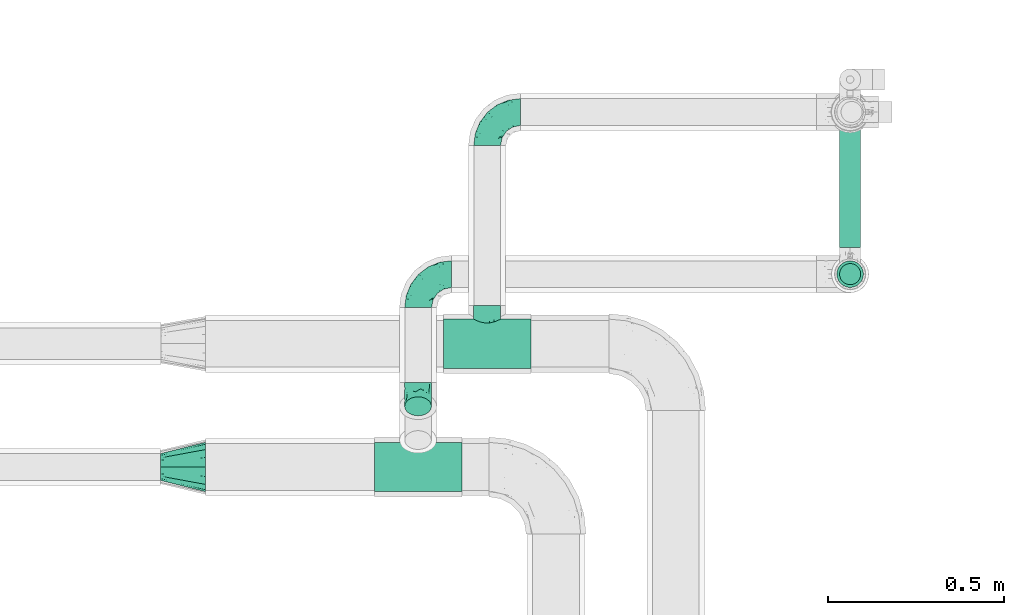
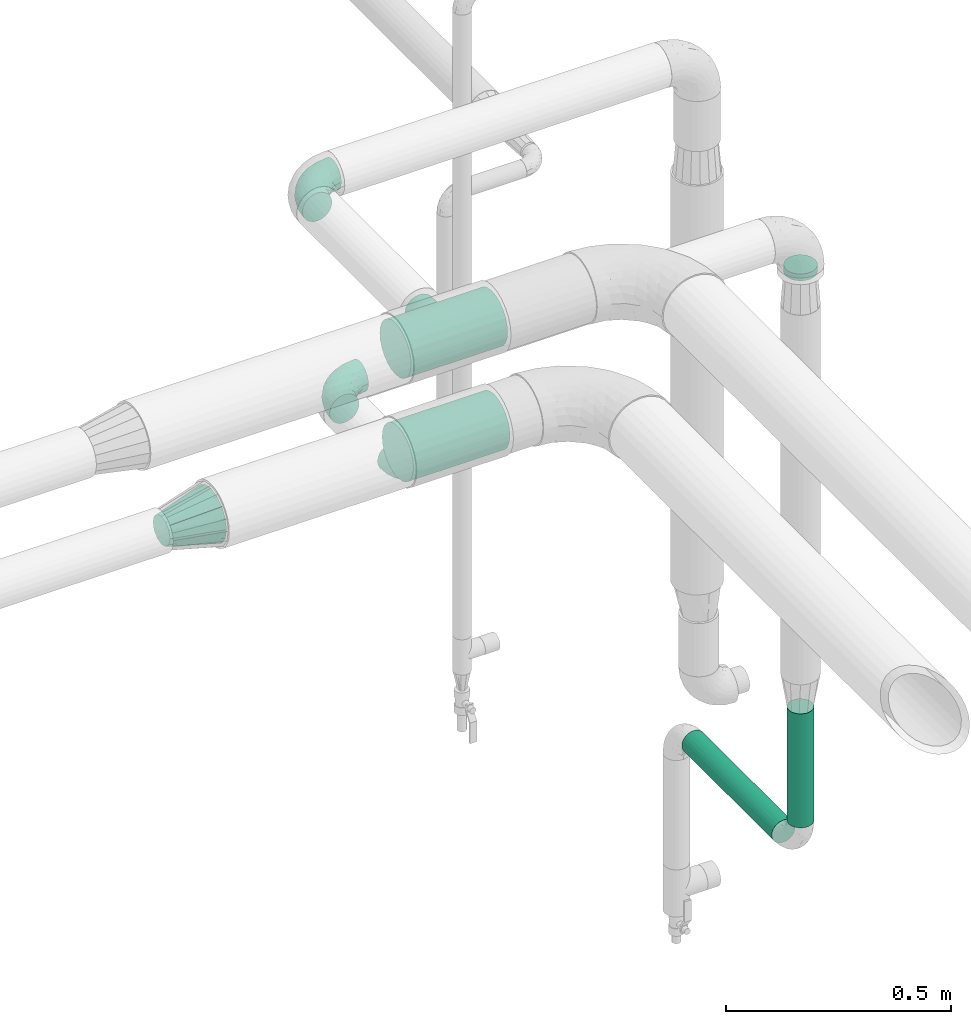
# One storey, part 583 of 827: 6 flow fittings, 3 flow segments.
"""IFC2X3 building model written with IfcOpenShell, lengths in millimetres."""

from ifc_helpers import new_model, entity, si_unit, converted_unit, derived_unit, direction, frame, origin, origin_2d_with_axis, place, context, subcontext, project, spatial, circle, extrude, faceted_brep, source, transform, mapped, material, type_object, type_shapes, element, save


model = new_model("IFC2X3")

# Units and contexts
model_context = context("Model", 3, precision=0.01, world=origin(), true_north=direction((6.12303176911189e-17, 1.0)))
body_context = subcontext(model_context, "Body", "Model", "MODEL_VIEW")
ifc_project = project(units=[si_unit("LENGTHUNIT", "METRE", prefix="MILLI"), si_unit("AREAUNIT", "SQUARE_METRE"), si_unit("VOLUMEUNIT", "CUBIC_METRE"), converted_unit("PLANEANGLEUNIT", "DEGREE", entity("IfcRatioMeasure", 0.0174532925199433), si_unit("PLANEANGLEUNIT", "RADIAN"), dimensions=[0, 0, 0, 0, 0, 0, 0]), si_unit("MASSUNIT", "GRAM", prefix="KILO"), derived_unit("MASSDENSITYUNIT", [(si_unit("MASSUNIT", "GRAM", prefix="KILO"), 1), (si_unit("LENGTHUNIT", "METRE"), -3)]), derived_unit("MOMENTOFINERTIAUNIT", [(si_unit("LENGTHUNIT", "METRE"), 4)]), si_unit("TIMEUNIT", "SECOND"), si_unit("FREQUENCYUNIT", "HERTZ"), si_unit("THERMODYNAMICTEMPERATUREUNIT", "DEGREE_CELSIUS"), derived_unit("THERMALTRANSMITTANCEUNIT", [(si_unit("MASSUNIT", "GRAM", prefix="KILO"), 1), (si_unit("THERMODYNAMICTEMPERATUREUNIT", "KELVIN"), -1), (si_unit("TIMEUNIT", "SECOND"), -3)]), derived_unit("VOLUMETRICFLOWRATEUNIT", [(si_unit("LENGTHUNIT", "METRE"), 3), (si_unit("TIMEUNIT", "SECOND"), -1)]), derived_unit("MASSFLOWRATEUNIT", [(si_unit("MASSUNIT", "GRAM", prefix="KILO"), 1), (si_unit("TIMEUNIT", "SECOND"), -1)]), derived_unit("ROTATIONALFREQUENCYUNIT", [(si_unit("TIMEUNIT", "SECOND"), -1)]), si_unit("ELECTRICCURRENTUNIT", "AMPERE"), si_unit("ELECTRICVOLTAGEUNIT", "VOLT"), si_unit("POWERUNIT", "WATT"), si_unit("FORCEUNIT", "NEWTON", prefix="KILO"), si_unit("ILLUMINANCEUNIT", "LUX"), si_unit("LUMINOUSFLUXUNIT", "LUMEN"), si_unit("LUMINOUSINTENSITYUNIT", "CANDELA"), derived_unit("USERDEFINED", [(si_unit("MASSUNIT", "GRAM", prefix="KILO"), -1), (si_unit("LENGTHUNIT", "METRE"), -2), (si_unit("TIMEUNIT", "SECOND"), 3), (si_unit("LUMINOUSFLUXUNIT", "LUMEN"), 1)]), derived_unit("LINEARVELOCITYUNIT", [(si_unit("LENGTHUNIT", "METRE"), 1), (si_unit("TIMEUNIT", "SECOND"), -1)]), si_unit("PRESSUREUNIT", "PASCAL"), derived_unit("USERDEFINED", [(si_unit("LENGTHUNIT", "METRE"), -2), (si_unit("MASSUNIT", "GRAM", prefix="KILO"), 1), (si_unit("TIMEUNIT", "SECOND"), -2)]), derived_unit("LINEARFORCEUNIT", [(si_unit("MASSUNIT", "GRAM", prefix="KILO"), 1), (si_unit("LENGTHUNIT", "METRE"), 1), (si_unit("TIMEUNIT", "SECOND"), -2), (si_unit("LENGTHUNIT", "METRE"), -1)]), derived_unit("PLANARFORCEUNIT", [(si_unit("MASSUNIT", "GRAM", prefix="KILO"), 1), (si_unit("LENGTHUNIT", "METRE"), 1), (si_unit("TIMEUNIT", "SECOND"), -2), (si_unit("LENGTHUNIT", "METRE"), -2)])], contexts=[model_context])

# Site, building, storey
site_placement = place(None, origin())
site = spatial("IfcSite", under=ifc_project, at=site_placement, CompositionType="ELEMENT")
building_placement = place(site_placement, origin())
building = spatial("IfcBuilding", under=site, at=building_placement, CompositionType="ELEMENT")
storey_placement = place(building_placement, frame((0.0, 0.0, 28200.0)))
storey = spatial("IfcBuildingStorey", under=building, at=storey_placement, Name="08", CompositionType="ELEMENT", Elevation=28200.0)

# Flow segments
pipe_segment_type = type_object("IfcPipeSegmentType", PredefinedType="NOTDEFINED")
flow_segment_1_placement = place(storey_placement, frame((22630.11, 14907.9, 2486.5)))
element("IfcFlowSegment", 1, at=flow_segment_1_placement, inside=storey, type_object=pipe_segment_type, context=body_context, shape_type="SweptSolid", body=[
    extrude(circle(Radius=37.75, at=origin_2d_with_axis()), frame((39.35, 39.35, 0.0)), (0.0, 0.0, 1.0), 18.5029617016286),
])
flow_segment_2_placement = place(storey_placement, frame((22637.86, 14915.65, 996.55)))
element("IfcFlowSegment", 2, at=flow_segment_2_placement, inside=storey, type_object=pipe_segment_type, context=body_context, shape_type="SweptSolid", body=[
    extrude(circle(Radius=30.0, at=origin_2d_with_axis()), frame((31.6, 31.6, 0.0), z_axis=(0.0, 0.0, 1.0), x_axis=(-1.0, 0.0, 0.0)), (0.0, 0.0, 1.0), 309.000000000012),
])
flow_segment_3_placement = place(storey_placement, frame((22637.86, 15023.25, 888.96)))
element("IfcFlowSegment", 3, at=flow_segment_3_placement, inside=storey, type_object=pipe_segment_type, context=body_context, shape_type="SweptSolid", body=[
    extrude(circle(Radius=30.0, at=origin_2d_with_axis()), frame((31.6, 0.0, 31.6), z_axis=(0.0, 1.0, 0.0), x_axis=(1.0, 0.0, 0.0)), (0.0, 0.0, 1.0), 400.085432468071),
])

# Flow fittings
ifc_material = material()
pipe_fitting_type_1 = type_object("IfcPipeFittingType", Name="ADSK_1", PredefinedType="NOTDEFINED", material=ifc_material)
shared_shape_1 = source(origin(), body_context, "Body", "Brep", [
    faceted_brep([(-95.0, 19.02, -32.95), (-95.0, 9.85, -36.75), (-95.0, 0.0, -38.05), (-95.0, -9.85, -36.75), (-95.0, -19.03, -32.95), (-95.0, -26.91, -26.91), (-95.0, -32.95, -19.03), (-95.0, -36.75, -9.85), (-95.0, -38.05, 0.0), (-95.0, -36.75, 9.85), (-95.0, -32.95, 19.02), (-95.0, -26.91, 26.91), (-95.0, -19.03, 32.95), (-95.0, -9.85, 36.75), (-95.0, 0.0, 38.05), (-95.0, 9.85, 36.75), (-95.0, 19.02, 32.95), (-95.0, 26.91, 26.91), (-95.0, 32.95, 19.02), (-95.0, 36.75, 9.85), (-95.0, 38.05, 0.0), (-95.0, 36.75, -9.85), (-95.0, 32.95, -19.03), (-95.0, 26.91, -26.91), (0.0, 95.0, -38.05), (-9.85, 95.0, -36.75), (-19.02, 95.0, -32.95), (-26.91, 95.0, -26.91), (-32.95, 95.0, -19.03), (-36.75, 95.0, -9.85), (-38.05, 95.0, 0.0), (-36.75, 95.0, 9.85), (-32.95, 95.0, 19.02), (-26.91, 95.0, 26.91), (-19.02, 95.0, 32.95), (-9.85, 95.0, 36.75), (0.0, 95.0, 38.05), (9.85, 95.0, 36.75), (19.03, 95.0, 32.95), (26.91, 95.0, 26.91), (32.95, 95.0, 19.02), (36.75, 95.0, 9.85), (38.05, 95.0, 0.0), (36.75, 95.0, -9.85), (32.95, 95.0, -19.03), (26.91, 95.0, -26.91), (19.03, 95.0, -32.95), (9.85, 95.0, -36.75), (-7.99, -4.96, 6.3), (-0.92, 0.92, 0.0), (4.62, 8.1, 8.01), (-76.19, -35.57, 0.0), (-64.32, -32.32, 12.43), (20.51, 62.45, 28.68), (-60.56, -33.52, 0.0), (-70.4, -13.47, 34.42), (-39.61, -5.88, 32.32), (-49.6, 2.07, 37.1), (-70.34, -28.81, 21.71), (14.64, 40.81, 26.5), (5.88, 39.61, 32.32), (3.59, 20.77, 25.31), (-40.45, 68.06, 16.75), (-62.45, -20.51, 28.68), (-44.52, -26.87, 0.0), (-28.47, -20.22, 0.0), (-26.43, -17.83, 8.75), (-76.1, 39.63, 10.76), (-72.74, 37.58, 18.19), (-60.35, 46.18, 14.61), (-13.4, 13.4, 32.12), (-20.77, -3.59, 25.31), (-14.66, 81.47, 35.56), (-6.22, 71.26, 37.92), (-57.5, 42.48, 22.79), (-15.0, 34.74, 37.7), (-27.1, 12.08, 36.05), (-9.2, 28.81, 35.63), (-79.98, 23.7, 30.95), (-73.68, -4.3, 37.48), (-30.74, 21.67, 37.97), (-62.36, 47.59, 6.79), (-72.71, 32.83, 24.69), (-67.42, 7.02, 37.95), (-32.13, 75.27, 24.51), (-43.46, 51.47, 26.26), (-24.98, 73.15, 31.29), (20.59, 41.28, 19.85), (7.79, 16.09, 15.86), (-73.21, 42.39, 0.0), (-54.73, 54.73, 0.0), (-73.44, 15.79, 35.79), (-5.94, 4.32, 20.43), (28.81, 70.34, 21.71), (32.32, 64.32, 12.43), (-53.59, 26.2, 35.09), (-52.02, 19.31, 37.21), (21.38, 33.53, 10.34), (26.87, 44.52, 0.0), (-48.28, 12.14, 38.05), (4.3, 73.68, 37.48), (-44.08, -25.52, 12.79), (-41.28, -20.59, 19.85), (35.57, 76.19, 0.0), (-47.26, 54.3, 20.18), (-47.4, 61.99, 8.58), (-42.39, 73.21, 0.0), (-39.67, 78.86, 7.21), (-45.69, 36.84, 33.11), (-32.83, 50.13, 33.35), (13.47, 70.4, 34.42), (-18.25, 63.73, 36.07), (-40.63, -13.75, 27.22), (-16.63, 46.37, 37.95), (-53.47, 38.79, 28.59), (-26.07, 48.54, 36.15), (-34.51, 34.51, 36.86), (-2.07, 49.6, 37.1), (-22.79, -10.49, 19.23), (-61.73, 28.67, 31.87), (9.65, 14.7, 0.0), (20.22, 28.47, 0.0), (33.52, 60.56, 0.0), (-11.42, -5.44, 13.25), (-14.7, -9.65, 0.0), (-81.47, 14.66, -35.56), (-62.45, -20.51, -28.68), (-71.26, 6.22, -37.92), (-75.27, 32.13, -24.51), (-73.15, 24.98, -31.29), (13.47, 70.4, -34.42), (5.88, 39.61, -32.32), (-2.07, 49.6, -37.1), (-78.86, 39.67, -7.21), (-70.4, -13.47, -34.42), (-39.61, -5.88, -32.32), (-61.99, 47.4, -8.58), (32.32, 64.32, -12.43), (28.81, 70.34, -21.71), (-63.73, 18.25, -36.07), (-50.13, 32.83, -33.35), (4.3, 73.68, -37.48), (-7.02, 67.42, -37.95), (-39.63, 76.1, -10.76), (-46.18, 60.35, -14.61), (-47.59, 62.36, -6.79), (-64.32, -32.32, -12.43), (-26.2, 53.59, -35.09), (-15.79, 73.44, -35.79), (-19.31, 52.02, -37.21), (-37.58, 72.74, -18.19), (-70.34, -28.81, -21.71), (-42.48, 57.5, -22.79), (-38.79, 53.47, -28.59), (-51.47, 43.46, -26.26), (-32.83, 72.71, -24.69), (-46.37, 16.63, -37.95), (-73.68, -4.3, -37.48), (-41.28, -20.59, -19.85), (-44.08, -25.52, -12.79), (13.75, 40.63, -27.22), (20.51, 62.45, -28.68), (-68.06, 40.45, -16.75), (-54.3, 47.26, -20.18), (-12.14, 48.28, -38.05), (-21.67, 30.74, -37.97), (-36.84, 45.69, -33.11), (-11.42, -5.44, -13.25), (7.79, 16.09, -15.86), (4.62, 8.1, -8.01), (-23.7, 79.98, -30.95), (-26.43, -17.83, -8.75), (-7.99, -4.96, -6.3), (-40.81, -14.64, -26.5), (-20.77, -3.59, -25.31), (-34.74, 15.0, -37.7), (-12.08, 27.1, -36.05), (-28.81, 9.2, -35.63), (-22.79, -10.49, -19.23), (21.38, 33.53, -10.34), (20.59, 41.28, -19.85), (-48.54, 26.07, -36.15), (-49.6, 2.07, -37.1), (-13.4, 13.4, -32.12), (3.59, 20.77, -25.31), (-28.67, 61.73, -31.87), (-34.51, 34.51, -36.86), (-5.94, 4.32, -20.43)], [[[0, 1, 2, 3, 4, 5, 6, 7, 8, 9, 10, 11, 12, 13, 14, 15, 16, 17, 18, 19, 20, 21, 22, 23]], [[24, 25, 26, 27, 28, 29, 30, 31, 32, 33, 34, 35, 36, 37, 38, 39, 40, 41, 42, 43, 44, 45, 46, 47]], [[48, 49, 50]], [[51, 52, 9]], [[53, 39, 38]], [[9, 52, 10]], [[54, 52, 51]], [[55, 56, 57]], [[11, 10, 58]], [[59, 60, 61]], [[32, 31, 62]], [[63, 12, 11]], [[63, 55, 12]], [[64, 65, 66]], [[67, 68, 69]], [[70, 56, 71]], [[35, 72, 73]], [[69, 68, 74]], [[75, 76, 77]], [[16, 78, 17]], [[13, 79, 14]], [[76, 75, 80]], [[67, 69, 81]], [[18, 17, 82]], [[14, 79, 83]], [[20, 19, 67]], [[84, 85, 86]], [[87, 61, 88]], [[89, 81, 90]], [[18, 82, 68]], [[15, 91, 16]], [[14, 83, 15]], [[71, 92, 61]], [[17, 78, 82]], [[93, 87, 94]], [[95, 91, 96]], [[97, 98, 94]], [[86, 72, 34]], [[96, 99, 80]], [[37, 36, 100]], [[40, 39, 93]], [[40, 94, 41]], [[64, 66, 101]], [[93, 94, 40]], [[58, 102, 63]], [[94, 103, 41]], [[94, 87, 97]], [[104, 69, 74]], [[34, 33, 86]], [[105, 69, 104]], [[52, 58, 10]], [[106, 107, 30]], [[108, 109, 85]], [[105, 106, 90]], [[53, 110, 60]], [[86, 111, 72]], [[86, 109, 111]], [[33, 84, 86]], [[12, 55, 13]], [[112, 56, 63]], [[110, 38, 37]], [[34, 72, 35]], [[36, 35, 73]], [[111, 113, 73]], [[105, 107, 106]], [[110, 53, 38]], [[74, 114, 85]], [[91, 15, 83]], [[105, 90, 81]], [[107, 62, 31]], [[33, 32, 84]], [[115, 109, 116]], [[111, 115, 113]], [[100, 73, 117]], [[56, 55, 63]], [[79, 55, 57]], [[102, 118, 112]], [[56, 70, 76]], [[100, 110, 37]], [[117, 77, 60]], [[117, 60, 110]], [[60, 70, 61]], [[58, 52, 101]], [[63, 11, 58]], [[39, 53, 93]], [[87, 93, 53]], [[96, 91, 83]], [[78, 91, 119]], [[32, 62, 84]], [[84, 62, 104]], [[86, 85, 109]], [[85, 114, 108]], [[80, 113, 116]], [[117, 73, 113]], [[80, 116, 96]], [[80, 57, 76]], [[71, 112, 118]], [[61, 87, 59]], [[62, 107, 105]], [[97, 120, 121]], [[70, 71, 61]], [[71, 118, 92]], [[73, 100, 36]], [[110, 100, 117]], [[55, 79, 13]], [[83, 79, 57]], [[96, 83, 99]], [[116, 108, 95]], [[50, 97, 88]], [[97, 87, 88]], [[50, 49, 120]], [[122, 94, 98]], [[89, 20, 67]], [[105, 81, 69]], [[89, 67, 81]], [[68, 19, 18]], [[68, 67, 19]], [[74, 68, 82]], [[114, 82, 119]], [[74, 85, 104]], [[82, 114, 74]], [[114, 119, 108]], [[95, 108, 119]], [[116, 109, 108]], [[123, 48, 50]], [[97, 50, 120]], [[123, 50, 88]], [[91, 95, 119]], [[116, 95, 96]], [[84, 104, 85]], [[104, 62, 105]], [[83, 57, 99]], [[57, 80, 99]], [[66, 48, 123]], [[66, 124, 48]], [[118, 66, 123]], [[124, 66, 65]], [[66, 118, 101]], [[54, 64, 52]], [[124, 49, 48]], [[30, 107, 31]], [[91, 78, 16]], [[82, 78, 119]], [[56, 76, 57]], [[77, 76, 70]], [[60, 77, 70]], [[77, 117, 75]], [[117, 113, 75]], [[113, 80, 75]], [[9, 8, 51]], [[103, 94, 122]], [[103, 42, 41]], [[73, 72, 111]], [[113, 115, 116]], [[111, 109, 115]], [[102, 112, 63]], [[71, 56, 112]], [[118, 102, 101]], [[92, 123, 88]], [[123, 92, 118]], [[61, 92, 88]], [[87, 53, 59]], [[60, 59, 53]], [[97, 121, 98]], [[58, 101, 102]], [[64, 101, 52]], [[125, 1, 0]], [[126, 5, 4]], [[2, 1, 127]], [[1, 125, 127]], [[128, 129, 23]], [[130, 131, 132]], [[89, 133, 20]], [[126, 134, 135]], [[136, 89, 90]], [[137, 138, 44]], [[139, 129, 140]], [[24, 141, 142]], [[143, 144, 145]], [[125, 129, 139]], [[6, 146, 7]], [[147, 148, 149]], [[146, 51, 7]], [[143, 150, 144]], [[146, 6, 151]], [[152, 153, 154]], [[126, 4, 134]], [[0, 23, 129]], [[28, 155, 150]], [[43, 42, 103]], [[54, 146, 64]], [[139, 156, 127]], [[157, 3, 2]], [[151, 158, 159]], [[160, 131, 161]], [[22, 21, 162]], [[136, 144, 163]], [[149, 164, 165]], [[24, 142, 25]], [[166, 140, 154]], [[154, 129, 128]], [[143, 30, 29]], [[167, 168, 169]], [[155, 28, 27]], [[26, 170, 27]], [[171, 167, 172]], [[26, 25, 148]], [[27, 170, 155]], [[173, 135, 174]], [[144, 150, 152]], [[175, 176, 177]], [[24, 47, 141]], [[45, 161, 46]], [[148, 25, 142]], [[176, 175, 165]], [[64, 159, 171]], [[138, 45, 44]], [[130, 46, 161]], [[137, 44, 43]], [[178, 159, 158]], [[137, 103, 122]], [[163, 144, 152]], [[136, 133, 89]], [[103, 137, 43]], [[6, 5, 151]], [[178, 158, 173]], [[134, 4, 3]], [[178, 173, 174]], [[137, 98, 179]], [[145, 90, 106]], [[138, 180, 161]], [[46, 130, 47]], [[136, 90, 145]], [[133, 162, 21]], [[23, 22, 128]], [[139, 140, 181]], [[139, 181, 156]], [[157, 127, 182]], [[157, 134, 3]], [[182, 177, 135]], [[182, 135, 134]], [[135, 183, 174]], [[131, 130, 161]], [[141, 130, 132]], [[160, 180, 184]], [[131, 183, 176]], [[5, 126, 151]], [[158, 151, 126]], [[180, 138, 137]], [[161, 45, 138]], [[149, 148, 142]], [[170, 148, 185]], [[22, 162, 128]], [[128, 162, 163]], [[129, 154, 140]], [[154, 153, 166]], [[165, 156, 186]], [[182, 127, 156]], [[165, 186, 149]], [[165, 132, 176]], [[131, 184, 183]], [[187, 167, 178]], [[184, 168, 187]], [[167, 169, 172]], [[184, 180, 168]], [[174, 183, 184]], [[127, 157, 2]], [[134, 157, 182]], [[130, 141, 47]], [[142, 141, 132]], [[149, 142, 164]], [[186, 166, 147]], [[180, 179, 168]], [[169, 179, 120]], [[137, 179, 180]], [[179, 121, 120]], [[106, 30, 143]], [[136, 145, 144]], [[106, 143, 145]], [[150, 29, 28]], [[150, 143, 29]], [[152, 150, 155]], [[153, 155, 185]], [[152, 154, 163]], [[155, 153, 152]], [[153, 185, 166]], [[147, 166, 185]], [[186, 140, 166]], [[169, 120, 49]], [[169, 49, 172]], [[179, 169, 168]], [[148, 147, 185]], [[186, 147, 149]], [[128, 163, 154]], [[163, 162, 136]], [[142, 132, 164]], [[132, 165, 164]], [[171, 124, 65]], [[124, 171, 172]], [[64, 146, 159]], [[171, 159, 178]], [[171, 65, 64]], [[172, 49, 124]], [[162, 133, 136]], [[20, 133, 21]], [[148, 170, 26]], [[155, 170, 185]], [[131, 176, 132]], [[177, 176, 183]], [[135, 177, 183]], [[177, 182, 175]], [[182, 156, 175]], [[156, 165, 175]], [[51, 146, 54]], [[51, 8, 7]], [[129, 125, 0]], [[127, 125, 139]], [[140, 186, 181]], [[156, 181, 186]], [[158, 126, 173]], [[135, 173, 126]], [[187, 178, 174]], [[171, 178, 167]], [[184, 187, 174]], [[167, 187, 168]], [[180, 160, 161]], [[184, 131, 160]], [[98, 137, 122]], [[98, 121, 179]], [[151, 159, 146]]]),
])
type_shapes(pipe_fitting_type_1, [shared_shape_1])
for number, where, z_axis, x_axis, name in (
    (4, (21639.46, 15407.25, 2799.93), (0.0, 0.0, 1.0), (-1.0, 0.0, 0.0), "ADSK_1"),
    (5, (21443.56, 14947.25, 2600.0), (0.0, 0.0, 1.0), (-1.0, 0.0, 0.0), "ADSK_1"),
):
    element("IfcFlowFitting", number, at=place(storey_placement, frame(where, z_axis=z_axis, x_axis=x_axis)), inside=storey, type_object=pipe_fitting_type_1, material=ifc_material, Name=name, ObjectType="ADSK_1", context=body_context, shape_type="MappedRepresentation", body=[
        mapped(shared_shape_1, transform((0.0, 0.0, 0.0), scale=1.0)),
    ])
pipe_fitting_type_2 = type_object("IfcPipeFittingType", Name="ADSK_1", PredefinedType="NOTDEFINED", material=ifc_material)
shared_shape_2 = source(origin(), body_context, "Body", "Brep", [
    faceted_brep([(127.0, 32.95, 19.03), (127.0, 25.99, 25.99), (127.0, 19.02, 32.95), (127.0, 9.51, 35.5), (127.0, 0.0, 38.05), (127.0, -9.51, 35.5), (127.0, -19.03, 32.95), (127.0, -25.99, 25.99), (127.0, -32.95, 19.03), (127.0, -35.5, 9.51), (127.0, -38.05, 0.0), (127.0, -35.5, -9.51), (127.0, -32.95, -19.02), (127.0, -25.99, -25.99), (127.0, -19.03, -32.95), (127.0, -9.51, -35.5), (127.0, 0.0, -38.05), (127.0, 9.51, -35.5), (127.0, 19.02, -32.95), (127.0, 25.99, -25.99), (127.0, 32.95, -19.02), (127.0, 35.5, -9.51), (127.0, 38.05, 0.0), (127.0, 35.5, 9.51), (0.0, 38.06, 56.96), (0.0, 49.39, 49.39), (0.0, 56.96, 38.06), (0.0, 64.53, 26.73), (0.0, 67.19, 13.37), (0.0, 69.85, 0.0), (0.0, 67.19, -13.37), (0.0, 64.53, -26.73), (0.0, 56.96, -38.06), (0.0, 49.39, -49.39), (0.0, 38.06, -56.96), (0.0, 26.73, -64.53), (0.0, 13.37, -67.19), (0.0, 0.0, -69.85), (0.0, -13.37, -67.19), (0.0, -26.73, -64.53), (0.0, -38.06, -56.96), (0.0, -49.39, -49.39), (0.0, -56.96, -38.06), (0.0, -64.53, -26.73), (0.0, -67.19, -13.37), (0.0, -69.85, 0.0), (0.0, -67.19, 13.37), (0.0, -64.53, 26.73), (0.0, -56.96, 38.06), (0.0, -49.39, 49.39), (0.0, -38.06, 56.96), (0.0, -26.73, 64.53), (0.0, -13.37, 67.19), (0.0, 0.0, 69.85), (0.0, 13.37, 67.19), (0.0, 26.73, 64.53)], [[[0, 1, 2, 3, 4, 5, 6, 7, 8, 9, 10, 11, 12, 13, 14, 15, 16, 17, 18, 19, 20, 21, 22, 23]], [[24, 25, 26, 27, 28, 29, 30, 31, 32, 33, 34, 35, 36, 37, 38, 39, 40, 41, 42, 43, 44, 45, 46, 47, 48, 49, 50, 51, 52, 53, 54, 55]], [[30, 29, 22]], [[16, 15, 38]], [[18, 35, 34]], [[15, 39, 38]], [[13, 12, 42]], [[13, 40, 14]], [[16, 36, 17]], [[40, 13, 41]], [[35, 18, 17]], [[21, 31, 30]], [[19, 32, 20]], [[19, 18, 34]], [[19, 34, 33]], [[40, 39, 14]], [[15, 14, 39]], [[38, 37, 16]], [[21, 20, 31]], [[12, 43, 42]], [[44, 10, 45]], [[32, 19, 33]], [[22, 21, 30]], [[10, 44, 11]], [[42, 41, 13]], [[32, 31, 20]], [[36, 35, 17]], [[43, 12, 11]], [[44, 43, 11]], [[36, 16, 37]], [[46, 45, 10]], [[4, 3, 54]], [[6, 51, 50]], [[3, 55, 54]], [[1, 0, 26]], [[1, 24, 2]], [[4, 52, 5]], [[24, 1, 25]], [[51, 6, 5]], [[9, 47, 46]], [[7, 48, 8]], [[7, 6, 50]], [[7, 50, 49]], [[24, 55, 2]], [[3, 2, 55]], [[54, 53, 4]], [[9, 8, 47]], [[0, 27, 26]], [[28, 22, 29]], [[48, 7, 49]], [[10, 9, 46]], [[22, 28, 23]], [[26, 25, 1]], [[48, 47, 8]], [[52, 51, 5]], [[27, 0, 23]], [[28, 27, 23]], [[52, 4, 53]]]),
])
type_shapes(pipe_fitting_type_2, [shared_shape_2])
flow_fitting_1_placement = place(storey_placement, frame((20839.9, 14400.0, 2799.98), z_axis=(0.0, 0.0, 1.0), x_axis=(-1.0, 0.0, 0.0)))
element("IfcFlowFitting", 6, at=flow_fitting_1_placement, inside=storey, type_object=pipe_fitting_type_2, material=ifc_material, Name="ADSK_1", ObjectType="ADSK_1", context=body_context, shape_type="MappedRepresentation", body=[
    mapped(shared_shape_2, transform((0.0, 0.0, 0.0), scale=1.0)),
])
pipe_fitting_type_3 = type_object("IfcPipeFittingType", Name="ADSK_1", PredefinedType="NOTDEFINED", material=ifc_material)
shared_shape_3 = source(origin(), body_context, "Body", "Brep", [
    faceted_brep([(-124.0, 18.08, -67.47), (-124.0, 0.0, -69.85), (-124.0, -18.08, -67.47), (-124.0, -34.93, -60.49), (-124.0, -49.39, -49.39), (-124.0, -60.49, -34.93), (-124.0, -67.47, -18.08), (-124.0, -69.85, 0.0), (-124.0, -67.47, 18.08), (-124.0, -60.49, 34.92), (-124.0, -49.39, 49.39), (-124.0, -34.93, 60.49), (-124.0, -18.08, 67.47), (-124.0, 0.0, 69.85), (-124.0, 18.08, 67.47), (-124.0, 34.92, 60.49), (-124.0, 49.39, 49.39), (-124.0, 60.49, 34.92), (-124.0, 67.47, 18.08), (-124.0, 69.85, 0.0), (-124.0, 67.47, -18.08), (-124.0, 60.49, -34.93), (-124.0, 49.39, -49.39), (-124.0, 34.92, -60.49), (124.0, 49.39, -49.39), (124.0, 60.49, -34.93), (124.0, 67.47, -18.08), (124.0, 69.85, 0.0), (124.0, 67.47, 18.08), (124.0, 60.49, 34.92), (124.0, 49.39, 49.39), (124.0, 34.92, 60.49), (124.0, 18.08, 67.47), (124.0, 0.0, 69.85), (124.0, -18.08, 67.47), (124.0, -34.93, 60.49), (124.0, -49.39, 49.39), (124.0, -60.49, 34.92), (124.0, -67.47, 18.08), (124.0, -69.85, 0.0), (124.0, -67.47, -18.08), (124.0, -60.49, -34.93), (124.0, -49.39, -49.39), (124.0, -34.93, -60.49), (124.0, -18.08, -67.47), (124.0, 0.0, -69.85), (124.0, 18.08, -67.47), (124.0, 34.92, -60.49), (35.68, -68.59, 13.21), (36.87, -69.22, 6.61), (38.05, -69.85, 0.0), (29.07, -65.39, 24.55), (6.73, -58.96, 37.45), (19.15, -61.63, 32.88), (12.94, -60.29, 35.16), (-38.05, -69.85, 0.0), (-36.87, -69.22, 6.61), (-35.68, -68.59, 13.21), (-29.08, -65.4, 24.54), (-19.15, -61.63, 32.88), (-12.95, -60.3, 35.16), (-6.74, -58.96, 37.45), (-0.01, -58.96, 37.45), (6.73, -58.96, -37.45), (19.15, -61.63, -32.88), (12.94, -60.29, -35.16), (29.07, -65.39, -24.55), (35.68, -68.59, -13.21), (36.87, -69.22, -6.61), (-6.74, -58.96, -37.45), (-12.95, -60.3, -35.16), (-19.15, -61.63, -32.88), (-29.08, -65.4, -24.54), (-0.01, -58.96, -37.45), (-35.68, -68.59, -13.21), (-36.87, -69.22, -6.61), (9.85, -108.0, -36.75), (19.03, -108.0, -32.95), (26.91, -108.0, -26.91), (32.95, -108.0, -19.03), (36.75, -108.0, -9.85), (38.05, -108.0, 0.0), (36.75, -108.0, 9.85), (32.95, -108.0, 19.02), (26.91, -108.0, 26.91), (19.03, -108.0, 32.95), (9.85, -108.0, 36.75), (0.0, -108.0, 38.05), (-9.85, -108.0, 36.75), (-19.02, -108.0, 32.95), (-26.91, -108.0, 26.91), (-32.95, -108.0, 19.02), (-36.75, -108.0, 9.85), (-38.05, -108.0, 0.0), (-36.75, -108.0, -9.85), (-32.95, -108.0, -19.03), (-26.91, -108.0, -26.91), (-19.02, -108.0, -32.95), (-9.85, -108.0, -36.75), (0.0, -108.0, -38.05)], [[[0, 1, 2, 3, 4, 5, 6, 7, 8, 9, 10, 11, 12, 13, 14, 15, 16, 17, 18, 19, 20, 21, 22, 23]], [[24, 25, 26, 27, 28, 29, 30, 31, 32, 33, 34, 35, 36, 37, 38, 39, 40, 41, 42, 43, 44, 45, 46, 47]], [[39, 38, 48]], [[39, 48, 49, 50]], [[38, 51, 48]], [[37, 36, 52]], [[53, 51, 37]], [[37, 52, 54, 53]], [[36, 10, 52]], [[37, 51, 38]], [[7, 55, 56, 57]], [[8, 7, 57]], [[57, 58, 8]], [[9, 59, 60, 61]], [[59, 9, 58]], [[9, 61, 10]], [[58, 9, 8]], [[10, 61, 62, 52]], [[36, 35, 11, 10]], [[13, 12, 34, 33]], [[12, 11, 35, 34]], [[14, 13, 33, 32]], [[29, 28, 18, 17]], [[16, 15, 31, 30]], [[17, 16, 30, 29]], [[32, 31, 15, 14]], [[19, 18, 28, 27]], [[20, 26, 25, 21]], [[25, 24, 22, 21]], [[27, 26, 20, 19]], [[45, 44, 2, 1]], [[0, 23, 47, 46]], [[1, 0, 46, 45]], [[24, 47, 23, 22]], [[43, 3, 2, 44]], [[43, 42, 4, 3]], [[42, 41, 63]], [[41, 64, 65, 63]], [[41, 66, 64]], [[42, 63, 4]], [[40, 39, 67]], [[67, 66, 40]], [[39, 50, 68, 67]], [[40, 66, 41]], [[5, 69, 70, 71]], [[5, 4, 69]], [[71, 72, 5]], [[4, 63, 73, 69]], [[72, 74, 6]], [[74, 7, 6]], [[7, 74, 75, 55]], [[72, 6, 5]], [[76, 77, 78, 79, 80, 81, 82, 83, 84, 85, 86, 87, 88, 89, 90, 91, 92, 93, 94, 95, 96, 97, 98, 99]], [[56, 93, 92]], [[60, 89, 88]], [[59, 90, 89]], [[60, 59, 89]], [[87, 61, 88]], [[85, 54, 86]], [[92, 57, 56]], [[55, 93, 56]], [[57, 92, 91]], [[57, 91, 58]], [[49, 81, 50]], [[90, 58, 91]], [[90, 59, 58]], [[88, 61, 60]], [[87, 52, 62, 61]], [[85, 53, 54]], [[84, 53, 85]], [[48, 83, 82]], [[84, 83, 51]], [[52, 87, 86]], [[54, 52, 86]], [[49, 48, 82]], [[53, 84, 51]], [[51, 83, 48]], [[81, 49, 82]], [[80, 68, 81]], [[80, 67, 68]], [[65, 77, 76]], [[78, 66, 79]], [[80, 79, 67]], [[99, 63, 76]], [[64, 78, 77]], [[68, 50, 81]], [[67, 79, 66]], [[76, 63, 65]], [[64, 66, 78]], [[99, 69, 73, 63]], [[97, 70, 98]], [[75, 74, 94]], [[97, 71, 70]], [[75, 93, 55]], [[96, 71, 97]], [[74, 95, 94]], [[96, 95, 72]], [[69, 99, 98]], [[70, 69, 98]], [[71, 96, 72]], [[72, 95, 74]], [[93, 75, 94]], [[65, 64, 77]]]),
])
type_shapes(pipe_fitting_type_3, [shared_shape_3])
for number, where, z_axis, x_axis, name in (
    (7, (21639.46, 14749.79, 2799.93), (0.0, 0.0, -1.0), (1.0, 0.0, 0.0), "ADSK_1"),
    (8, (21443.56, 14400.0, 2799.98), (0.0, -0.707106781186556, -0.707106781186539), (1.0, 0.0, 0.0), "ADSK_1"),
):
    element("IfcFlowFitting", number, at=place(storey_placement, frame(where, z_axis=z_axis, x_axis=x_axis)), inside=storey, type_object=pipe_fitting_type_3, material=ifc_material, Name=name, ObjectType="ADSK_1", context=body_context, shape_type="MappedRepresentation", body=[
        mapped(shared_shape_3, transform((0.0, 0.0, 0.0), scale=1.0)),
    ])
pipe_fitting_type_4 = type_object("IfcPipeFittingType", Name="ADSK_1", PredefinedType="NOTDEFINED", material=ifc_material)
shared_shape_4 = source(origin(), body_context, "Body", "Brep", [
    faceted_brep([(-39.35, 19.02, -32.95), (-39.35, 9.85, -36.75), (-39.35, 0.0, -38.05), (-39.35, -9.85, -36.75), (-39.35, -19.03, -32.95), (-39.35, -26.91, -26.91), (-39.35, -32.95, -19.03), (-39.35, -36.75, -9.85), (-39.35, -38.05, 0.0), (-39.35, -36.75, 9.85), (-39.35, -32.95, 19.02), (-39.35, -26.91, 26.91), (-39.35, -19.03, 32.95), (-39.35, -9.85, 36.75), (-39.35, 0.0, 38.05), (-39.35, 9.85, 36.75), (-39.35, 19.02, 32.95), (-39.35, 26.91, 26.91), (-39.35, 32.95, 19.02), (-39.35, 36.75, 9.85), (-39.35, 38.05, 0.0), (-39.35, 36.75, -9.85), (-39.35, 32.95, -19.03), (-39.35, 26.91, -26.91), (27.82, 27.82, -38.05), (20.86, 34.79, -36.75), (14.37, 41.28, -32.95), (8.8, 46.85, -26.91), (4.52, 51.13, -19.03), (1.84, 53.81, -9.85), (0.92, 54.73, 0.0), (1.84, 53.81, 9.85), (4.52, 51.13, 19.02), (8.8, 46.85, 26.91), (14.37, 41.28, 32.95), (20.86, 34.79, 36.75), (27.82, 27.82, 38.05), (34.79, 20.86, 36.75), (41.28, 14.37, 32.95), (46.85, 8.8, 26.91), (51.13, 4.52, 19.02), (53.81, 1.84, 9.85), (54.73, 0.92, 0.0), (53.81, 1.84, -9.85), (51.13, 4.52, -19.03), (46.85, 8.8, -26.91), (41.28, 14.37, -32.95), (34.79, 20.86, -36.75), (-16.48, -28.6, 22.48), (-9.83, -32.19, 13.52), (8.97, -21.66, 21.67), (-20.54, -35.57, 0.0), (-4.91, -33.52, 0.0), (-13.54, -34.93, 6.65), (-11.41, -20.66, 29.54), (31.88, -8.57, 22.48), (-19.69, -13.48, 34.86), (3.15, -7.61, 34.49), (12.7, 20.76, 37.8), (-14.37, -2.8, 37.58), (-4.35, 10.49, 37.89), (-23.66, 5.7, 37.8), (22.68, -6.54, 29.54), (23.46, 4.39, 34.86), (-17.67, 16.65, 35.5), (-11.48, 27.71, 30.93), (-5.05, 36.47, 26.65), (11.57, -24.66, 14.82), (11.29, -27.26, 7.35), (-19.91, 32.6, 23.86), (-16.29, 39.33, 15.52), (34.27, -15.12, 6.65), (39.68, -10.63, 0.0), (-13.09, 43.52, 7.94), (12.14, 8.18, 37.58), (29.72, -15.81, 13.52), (2.92, 25.68, 35.46), (5.55, -13.39, 30.82), (-17.56, 42.39, 0.0), (-7.75, 40.18, 21.01), (11.13, -26.87, 0.0), (27.17, -20.22, 0.0), (-14.37, -2.8, -37.58), (-13.54, -34.93, -6.65), (11.26, -27.2, -7.7), (0.72, 24.27, -35.5), (-23.66, 5.7, -37.8), (-21.52, 40.03, -7.94), (-16.29, 39.33, -15.52), (22.68, -6.54, -29.54), (-22.21, 29.36, -26.65), (29.72, -15.81, -13.52), (-22.93, 33.89, -21.01), (-8.97, 37.13, -23.86), (12.14, 8.18, -37.58), (-20.22, 16.09, -35.46), (-9.83, -32.19, -13.52), (31.88, -8.57, -22.48), (-16.48, -28.6, -22.48), (8.97, -21.66, -21.67), (8.74, -25.75, -14.99), (-11.41, -20.66, -29.54), (5.55, -13.39, -30.82), (3.15, -7.61, -34.49), (-19.69, -13.48, -34.86), (-11.48, 27.71, -30.93), (34.27, -15.12, -6.65), (12.7, 20.76, -37.8), (23.46, 4.39, -34.86), (-4.35, 10.49, -37.89)], [[[0, 1, 2, 3, 4, 5, 6, 7, 8, 9, 10, 11, 12, 13, 14, 15, 16, 17, 18, 19, 20, 21, 22, 23]], [[24, 25, 26, 27, 28, 29, 30, 31, 32, 33, 34, 35, 36, 37, 38, 39, 40, 41, 42, 43, 44, 45, 46, 47]], [[48, 49, 50]], [[51, 52, 53]], [[12, 11, 54]], [[40, 39, 55]], [[56, 54, 57]], [[48, 11, 10]], [[36, 35, 58]], [[13, 12, 56]], [[59, 60, 61]], [[14, 13, 59]], [[62, 55, 39]], [[38, 37, 63]], [[61, 15, 14]], [[16, 64, 65]], [[9, 51, 53]], [[33, 66, 34]], [[67, 49, 68]], [[65, 17, 16]], [[18, 17, 69]], [[18, 69, 70]], [[19, 18, 70]], [[41, 71, 72]], [[73, 20, 19]], [[52, 68, 53]], [[49, 53, 68]], [[16, 15, 64]], [[36, 58, 74]], [[39, 38, 62]], [[57, 74, 59]], [[74, 37, 36]], [[66, 69, 65]], [[75, 40, 55]], [[60, 58, 76]], [[62, 38, 63]], [[17, 65, 69]], [[71, 41, 75]], [[49, 48, 10]], [[61, 64, 15]], [[77, 50, 62]], [[19, 70, 73]], [[10, 9, 49]], [[78, 73, 30]], [[48, 54, 11]], [[31, 73, 70]], [[57, 63, 74]], [[69, 66, 79]], [[55, 62, 50]], [[79, 70, 69]], [[56, 59, 13]], [[35, 34, 76]], [[76, 65, 64]], [[54, 77, 57]], [[60, 59, 74]], [[75, 41, 40]], [[54, 48, 50]], [[32, 31, 70]], [[75, 55, 50]], [[65, 76, 34]], [[60, 76, 64]], [[54, 56, 12]], [[59, 56, 57]], [[74, 63, 37]], [[62, 63, 57]], [[9, 8, 51]], [[68, 52, 80, 81]], [[9, 53, 49]], [[71, 68, 81]], [[68, 75, 67]], [[72, 71, 81]], [[72, 42, 41]], [[68, 71, 75]], [[59, 61, 14]], [[64, 61, 60]], [[76, 58, 35]], [[74, 58, 60]], [[30, 73, 31]], [[73, 78, 20]], [[50, 77, 54]], [[62, 57, 77]], [[34, 66, 65]], [[79, 33, 32]], [[33, 79, 66]], [[32, 70, 79]], [[75, 50, 67]], [[49, 67, 50]], [[3, 2, 82]], [[52, 83, 84]], [[26, 25, 85]], [[2, 1, 86]], [[21, 87, 88]], [[46, 45, 89]], [[0, 23, 90]], [[44, 43, 91]], [[92, 88, 93]], [[24, 47, 94]], [[29, 28, 88]], [[1, 0, 95]], [[83, 7, 96]], [[91, 97, 44]], [[98, 99, 100]], [[98, 96, 6]], [[5, 4, 101]], [[89, 102, 103]], [[7, 6, 96]], [[5, 98, 6]], [[104, 4, 3]], [[90, 93, 105]], [[101, 98, 5]], [[28, 27, 93]], [[20, 78, 87]], [[27, 105, 93]], [[30, 29, 87]], [[102, 99, 101]], [[105, 85, 95]], [[88, 22, 21]], [[28, 93, 88]], [[104, 101, 4]], [[85, 105, 26]], [[90, 92, 93]], [[86, 82, 2]], [[27, 26, 105]], [[43, 72, 106]], [[107, 25, 24]], [[108, 47, 46]], [[7, 83, 51]], [[44, 97, 45]], [[103, 108, 89]], [[97, 89, 45]], [[109, 107, 94]], [[99, 97, 91]], [[109, 94, 82]], [[106, 72, 81]], [[108, 94, 47]], [[103, 104, 82]], [[83, 96, 84]], [[103, 82, 94]], [[100, 91, 84]], [[107, 85, 25]], [[29, 88, 87]], [[109, 86, 95]], [[98, 101, 99]], [[89, 97, 99]], [[105, 95, 0]], [[109, 95, 85]], [[82, 104, 3]], [[101, 104, 103]], [[89, 108, 46]], [[94, 108, 103]], [[51, 83, 52]], [[51, 8, 7]], [[100, 84, 96]], [[106, 84, 91]], [[84, 81, 80, 52]], [[43, 42, 72]], [[84, 106, 81]], [[43, 106, 91]], [[95, 86, 1]], [[82, 86, 109]], [[94, 107, 24]], [[85, 107, 109]], [[20, 87, 21]], [[87, 78, 30]], [[99, 102, 89]], [[101, 103, 102]], [[0, 90, 105]], [[92, 23, 22]], [[23, 92, 90]], [[22, 88, 92]], [[98, 100, 96]], [[91, 100, 99]]]),
])
type_shapes(pipe_fitting_type_4, [shared_shape_4])
flow_fitting_2_placement = place(storey_placement, frame((21443.56, 14599.98, 2600.0), z_axis=(-1.0, 0.0, 0.0), x_axis=(0.0, -1.0, 0.0)))
element("IfcFlowFitting", 9, at=flow_fitting_2_placement, inside=storey, type_object=pipe_fitting_type_4, material=ifc_material, Name="ADSK_1", ObjectType="ADSK_1", context=body_context, shape_type="MappedRepresentation", body=[
    mapped(shared_shape_4, transform((0.0, 0.0, 0.0), scale=1.0)),
])

save(model, "model.ifc")
